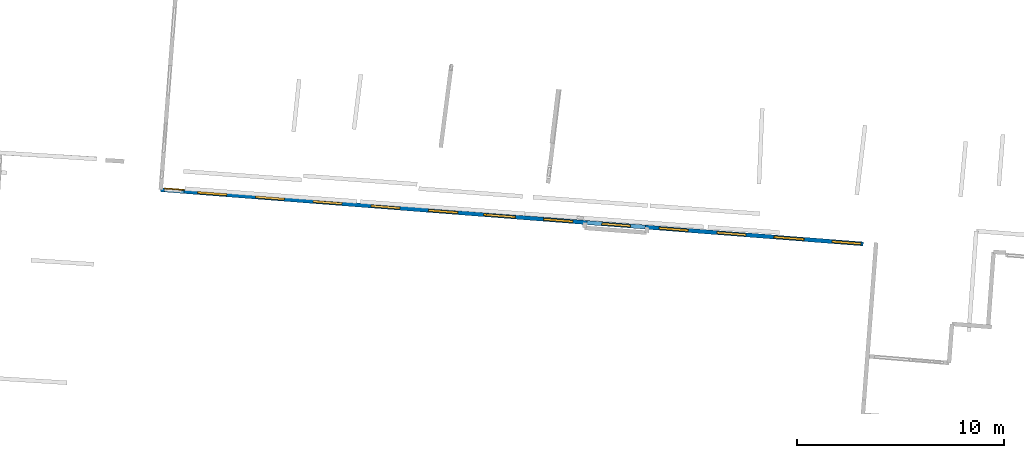
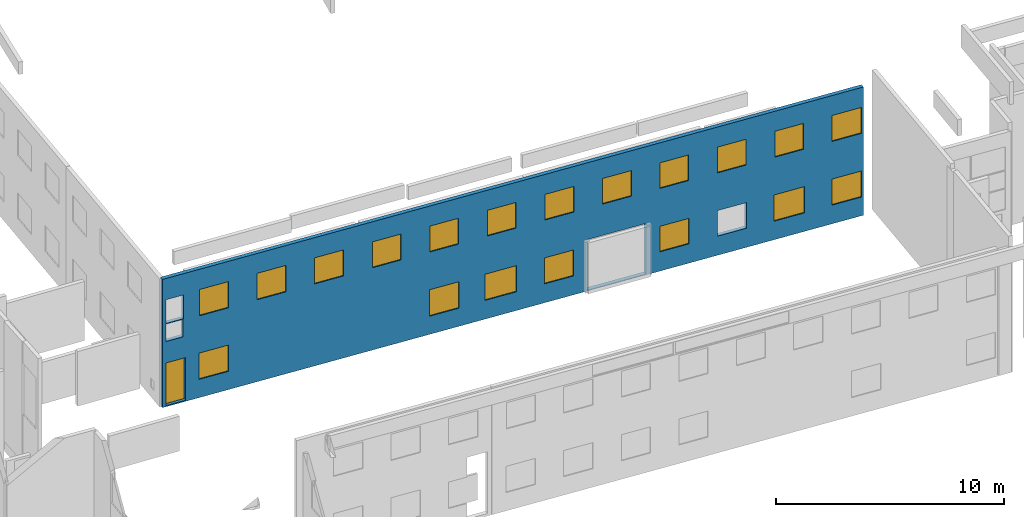
# One storey, part 12 of 27: 19 windows, 1 door, 1 wall, 24 openings.
"""IFC2X3 building model written with IfcOpenShell, lengths in metres."""

from ifc_helpers import new_model, entity, si_unit, converted_unit, derived_unit, direction, frame, frame_2d, origin, origin_2d_with_axis, place, context, subcontext, project, spatial, polyline, rectangle, outline, extrude, source, transform, mapped, material, layer, layer_set, layer_usage, type_object, type_shapes, element, fill, save


model = new_model("IFC2X3")

# Units and contexts
model_context = context("Model", 3, precision=1e-05, world=origin(), true_north=direction((0.0, 1.0)))
body_context = subcontext(model_context, "Body", "Model", "MODEL_VIEW")
ifc_project = project(units=[si_unit("LENGTHUNIT", "METRE"), si_unit("AREAUNIT", "SQUARE_METRE"), si_unit("VOLUMEUNIT", "CUBIC_METRE"), converted_unit("PLANEANGLEUNIT", "DEGREE", entity("IfcRatioMeasure", 0.0174532925199433), si_unit("PLANEANGLEUNIT", "RADIAN"), dimensions=[0, 0, 0, 0, 0, 0, 0]), si_unit("MASSUNIT", "GRAM", prefix="KILO"), derived_unit("MASSDENSITYUNIT", [(si_unit("MASSUNIT", "GRAM", prefix="KILO"), 1), (si_unit("LENGTHUNIT", "METRE"), -3)]), derived_unit("MOMENTOFINERTIAUNIT", [(si_unit("LENGTHUNIT", "METRE"), 4)]), si_unit("TIMEUNIT", "SECOND"), si_unit("FREQUENCYUNIT", "HERTZ"), si_unit("THERMODYNAMICTEMPERATUREUNIT", "DEGREE_CELSIUS"), derived_unit("THERMALTRANSMITTANCEUNIT", [(si_unit("MASSUNIT", "GRAM", prefix="KILO"), 1), (si_unit("THERMODYNAMICTEMPERATUREUNIT", "KELVIN"), -1), (si_unit("TIMEUNIT", "SECOND"), -3)]), derived_unit("VOLUMETRICFLOWRATEUNIT", [(si_unit("LENGTHUNIT", "METRE"), 3), (si_unit("TIMEUNIT", "SECOND"), -1)]), si_unit("ELECTRICCURRENTUNIT", "AMPERE"), si_unit("ELECTRICVOLTAGEUNIT", "VOLT"), si_unit("POWERUNIT", "WATT"), si_unit("FORCEUNIT", "NEWTON", prefix="KILO"), si_unit("ILLUMINANCEUNIT", "LUX"), si_unit("LUMINOUSFLUXUNIT", "LUMEN"), si_unit("LUMINOUSINTENSITYUNIT", "CANDELA"), derived_unit("USERDEFINED", [(si_unit("MASSUNIT", "GRAM", prefix="KILO"), -1), (si_unit("LENGTHUNIT", "METRE"), -2), (si_unit("TIMEUNIT", "SECOND"), 3), (si_unit("LUMINOUSFLUXUNIT", "LUMEN"), 1)]), derived_unit("LINEARVELOCITYUNIT", [(si_unit("LENGTHUNIT", "METRE"), 1), (si_unit("TIMEUNIT", "SECOND"), -1)]), si_unit("PRESSUREUNIT", "PASCAL"), derived_unit("USERDEFINED", [(si_unit("LENGTHUNIT", "METRE"), -2), (si_unit("MASSUNIT", "GRAM", prefix="KILO"), 1), (si_unit("TIMEUNIT", "SECOND"), -2)]), derived_unit("LINEARFORCEUNIT", [(si_unit("MASSUNIT", "GRAM", prefix="KILO"), 1), (si_unit("LENGTHUNIT", "METRE"), 1), (si_unit("TIMEUNIT", "SECOND"), -2), (si_unit("LENGTHUNIT", "METRE"), -1)]), derived_unit("PLANARFORCEUNIT", [(si_unit("MASSUNIT", "GRAM", prefix="KILO"), 1), (si_unit("LENGTHUNIT", "METRE"), 1), (si_unit("TIMEUNIT", "SECOND"), -2), (si_unit("LENGTHUNIT", "METRE"), -2)])], contexts=[model_context])

# Site, building, storey
placement_1 = place(None, origin())
site = spatial("IfcSite", under=ifc_project, at=placement_1, CompositionType="ELEMENT")
building = spatial("IfcBuilding", under=site, at=placement_1, CompositionType="ELEMENT")
storey_placement = place(placement_1, frame((0.0, 0.0, -61.043098449707)))
storey = spatial("IfcBuildingStorey", under=building, at=storey_placement, Name="level_-61.043098", CompositionType="ELEMENT", Elevation=-61.043098449707)

# Wall, openings, windows, door
ifc_material_1 = material(Name="Default wall")
ifc_layer = layer(ifc_material_1, 0.2)
ifc_layer_set = layer_set([ifc_layer], Name="wall_thickness_0.2000")
ifc_layer_usage = layer_usage(ifc_layer_set, "AXIS2", "POSITIVE", -0.1)
wall_type = type_object("IfcWallType", Name="wall_thickness_0.2000", PredefinedType="STANDARD", material=ifc_layer_set)
placement_2 = place(placement_1, frame((0.0, 0.0, -61.0783157348633)))
wall_placement = place(placement_2, frame((-70.5410936106186, 0.364161913204613, 0.0), z_axis=(0.0, 0.0, 1.0), x_axis=(0.997031285356377, -0.0769975065869715, 0.0)))
wall = element("IfcWallStandardCase", 1, at=wall_placement, inside=storey, type_object=wall_type, material=ifc_layer_usage, Name="Wall:863", ObjectType="Wall", context=body_context, shape_type="SweptSolid", body=[
    extrude(outline(polyline([(34.091740570846, -0.1), (34.091740570846, 0.1), (0.0, 0.1), (0.0, -0.1), (34.091740570846, -0.1)])), origin(), (0.0, 0.0, 1.0), 6.869140625),
])
opening_1_placement = place(wall_placement, frame((0.175669529657693, -0.1, 0.0593376159667969)))
opening_1 = element("IfcOpeningElement", 2, at=opening_1_placement, cuts=wall, Name="Opening : 950 x 2285 : 80", ObjectType="Opening", context=body_context, shape_type="SweptSolid", body=[
    extrude(rectangle(XDim=0.95, YDim=2.285, at=frame_2d((1.1425, 0.475), x_axis=(0.0, 1.0))), frame((0.0, 0.0, 0.0), z_axis=(0.0, 1.0, 0.0), x_axis=(0.0, 0.0, 1.0)), (0.0, 0.0, 1.0), 0.2),
])
opening_2_placement = place(wall_placement, frame((20.6733996380134, -0.1, 0.0425682067871094)))
element("IfcOpeningElement", 3, at=opening_2_placement, cuts=wall, Name="Opening : 2840 x 2715 : 81", ObjectType="Opening", context=body_context, shape_type="SweptSolid", body=[
    extrude(rectangle(XDim=2.84, YDim=2.715, at=frame_2d((1.3575, 1.42), x_axis=(0.0, 1.0))), frame((0.0, 0.0, 0.0), z_axis=(0.0, 1.0, 0.0), x_axis=(0.0, 0.0, 1.0)), (0.0, 0.0, 1.0), 0.2),
])
opening_3_placement = place(wall_placement, frame((21.4018079516808, -0.1, 4.43256759643555)))
opening_3 = element("IfcOpeningElement", 4, at=opening_3_placement, cuts=wall, Name="Opening : 1400 x 1370 : 82", ObjectType="Opening", context=body_context, shape_type="SweptSolid", body=[
    extrude(rectangle(XDim=1.4, YDim=1.37, at=frame_2d((0.685, 0.7), x_axis=(0.0, 1.0))), frame((0.0, 0.0, 0.0), z_axis=(0.0, 1.0, 0.0), x_axis=(0.0, 0.0, 1.0)), (0.0, 0.0, 1.0), 0.2),
])
opening_4_placement = place(wall_placement, frame((18.6005650597193, -0.1, 4.42756652832031)))
opening_4 = element("IfcOpeningElement", 5, at=opening_4_placement, cuts=wall, Name="Opening : 1405 x 1370 : 83", ObjectType="Opening", context=body_context, shape_type="SweptSolid", body=[
    extrude(rectangle(XDim=1.405, YDim=1.37, at=frame_2d((0.685, 0.7025), x_axis=(0.0, 1.0))), frame((0.0, 0.0, 0.0), z_axis=(0.0, 1.0, 0.0), x_axis=(0.0, 0.0, 1.0)), (0.0, 0.0, 1.0), 0.2),
])
opening_5_placement = place(wall_placement, frame((4.59927100477917, -0.1, 4.38933563232422)))
opening_5 = element("IfcOpeningElement", 6, at=opening_5_placement, cuts=wall, Name="Opening : 1410 x 1415 : 84", ObjectType="Opening", context=body_context, shape_type="SweptSolid", body=[
    extrude(rectangle(XDim=1.41, YDim=1.415, at=frame_2d((0.7075, 0.705), x_axis=(0.0, 1.0))), frame((0.0, 0.0, 0.0), z_axis=(0.0, 1.0, 0.0), x_axis=(0.0, 0.0, 1.0)), (0.0, 0.0, 1.0), 0.2),
])
opening_6_placement = place(wall_placement, frame((1.79896544522815, -0.1, 4.37933731079102)))
opening_6 = element("IfcOpeningElement", 7, at=opening_6_placement, cuts=wall, Name="Opening : 1405 x 1405 : 85", ObjectType="Opening", context=body_context, shape_type="SweptSolid", body=[
    extrude(rectangle(XDim=1.405, YDim=1.405, at=frame_2d((0.7025, 0.7025), x_axis=(0.0, 1.0))), frame((0.0, 0.0, 0.0), z_axis=(0.0, 1.0, 0.0), x_axis=(0.0, 0.0, 1.0)), (0.0, 0.0, 1.0), 0.2),
])
opening_7_placement = place(wall_placement, frame((7.40003180112796, -0.1, 4.39433670043945)))
opening_7 = element("IfcOpeningElement", 8, at=opening_7_placement, cuts=wall, Name="Opening : 1405 x 1395 : 86", ObjectType="Opening", context=body_context, shape_type="SweptSolid", body=[
    extrude(rectangle(XDim=1.405, YDim=1.395, at=frame_2d((0.6975, 0.7025), x_axis=(0.0, 1.0))), frame((0.0, 0.0, 0.0), z_axis=(0.0, 1.0, 0.0), x_axis=(0.0, 0.0, 1.0)), (0.0, 0.0, 1.0), 0.2),
])
opening_8_placement = place(wall_placement, frame((1.78067692275089, -0.1, 0.979335784912109)))
opening_8 = element("IfcOpeningElement", 9, at=opening_8_placement, cuts=wall, Name="Opening : 1420 x 1405 : 87", ObjectType="Opening", context=body_context, shape_type="SweptSolid", body=[
    extrude(rectangle(XDim=1.42, YDim=1.405, at=frame_2d((0.7025, 0.71), x_axis=(0.0, 1.0))), frame((0.0, 0.0, 0.0), z_axis=(0.0, 1.0, 0.0), x_axis=(0.0, 0.0, 1.0)), (0.0, 0.0, 1.0), 0.2),
])
opening_9_placement = place(wall_placement, frame((24.1869546370559, -0.1, 4.42756652832031)))
opening_9 = element("IfcOpeningElement", 10, at=opening_9_placement, cuts=wall, Name="Opening : 1400 x 1370 : 88", ObjectType="Opening", context=body_context, shape_type="SweptSolid", body=[
    extrude(rectangle(XDim=1.4, YDim=1.37, at=frame_2d((0.685, 0.7), x_axis=(0.0, 1.0))), frame((0.0, 0.0, 0.0), z_axis=(0.0, 1.0, 0.0), x_axis=(0.0, 0.0, 1.0)), (0.0, 0.0, 1.0), 0.2),
])
opening_10_placement = place(wall_placement, frame((29.7875311747154, -0.1, 4.41256713867188)))
opening_10 = element("IfcOpeningElement", 11, at=opening_10_placement, cuts=wall, Name="Opening : 1400 x 1385 : 89", ObjectType="Opening", context=body_context, shape_type="SweptSolid", body=[
    extrude(rectangle(XDim=1.4, YDim=1.385, at=frame_2d((0.6925, 0.7), x_axis=(0.0, 1.0))), frame((0.0, 0.0, 0.0), z_axis=(0.0, 1.0, 0.0), x_axis=(0.0, 0.0, 1.0)), (0.0, 0.0, 1.0), 0.2),
])
opening_11_placement = place(wall_placement, frame((32.5684003285411, -0.1, 4.41256713867188)))
opening_11 = element("IfcOpeningElement", 12, at=opening_11_placement, cuts=wall, Name="Opening : 1420 x 1390 : 90", ObjectType="Opening", context=body_context, shape_type="SweptSolid", body=[
    extrude(rectangle(XDim=1.42, YDim=1.39, at=frame_2d((0.695, 0.71), x_axis=(0.0, 1.0))), frame((0.0, 0.0, 0.0), z_axis=(0.0, 1.0, 0.0), x_axis=(0.0, 0.0, 1.0)), (0.0, 0.0, 1.0), 0.2),
])
opening_12_placement = place(wall_placement, frame((10.2015042481688, -0.1, 4.40756607055664)))
opening_12 = element("IfcOpeningElement", 13, at=opening_12_placement, cuts=wall, Name="Opening : 1405 x 1385 : 91", ObjectType="Opening", context=body_context, shape_type="SweptSolid", body=[
    extrude(rectangle(XDim=1.405, YDim=1.385, at=frame_2d((0.6925, 0.7025), x_axis=(0.0, 1.0))), frame((0.0, 0.0, 0.0), z_axis=(0.0, 1.0, 0.0), x_axis=(0.0, 0.0, 1.0)), (0.0, 0.0, 1.0), 0.2),
])
opening_13_placement = place(wall_placement, frame((12.9975627777284, -0.1, 4.40756607055664)))
opening_13 = element("IfcOpeningElement", 14, at=opening_13_placement, cuts=wall, Name="Opening : 1405 x 1385 : 92", ObjectType="Opening", context=body_context, shape_type="SweptSolid", body=[
    extrude(rectangle(XDim=1.405, YDim=1.385, at=frame_2d((0.6925, 0.7025), x_axis=(0.0, 1.0))), frame((0.0, 0.0, 0.0), z_axis=(0.0, 1.0, 0.0), x_axis=(0.0, 0.0, 1.0)), (0.0, 0.0, 1.0), 0.2),
])
opening_14_placement = place(wall_placement, frame((15.7978721303258, -0.1, 4.41756820678711)))
opening_14 = element("IfcOpeningElement", 15, at=opening_14_placement, cuts=wall, Name="Opening : 1405 x 1375 : 93", ObjectType="Opening", context=body_context, shape_type="SweptSolid", body=[
    extrude(rectangle(XDim=1.405, YDim=1.375, at=frame_2d((0.6875, 0.7025), x_axis=(0.0, 1.0))), frame((0.0, 0.0, 0.0), z_axis=(0.0, 1.0, 0.0), x_axis=(0.0, 0.0, 1.0)), (0.0, 0.0, 1.0), 0.2),
])
opening_15_placement = place(wall_placement, frame((26.9919317277781, -0.1, 4.41256713867188)))
opening_15 = element("IfcOpeningElement", 16, at=opening_15_placement, cuts=wall, Name="Opening : 1400 x 1380 : 94", ObjectType="Opening", context=body_context, shape_type="SweptSolid", body=[
    extrude(rectangle(XDim=1.4, YDim=1.38, at=frame_2d((0.69, 0.7), x_axis=(0.0, 1.0))), frame((0.0, 0.0, 0.0), z_axis=(0.0, 1.0, 0.0), x_axis=(0.0, 0.0, 1.0)), (0.0, 0.0, 1.0), 0.2),
])
opening_16_placement = place(wall_placement, frame((15.6733990489944, -0.1, 1.00256729125977)))
opening_16 = element("IfcOpeningElement", 17, at=opening_16_placement, cuts=wall, Name="Opening : 1535 x 1400 : 95", ObjectType="Opening", context=body_context, shape_type="SweptSolid", body=[
    extrude(rectangle(XDim=1.535, YDim=1.4, at=frame_2d((0.7, 0.7675), x_axis=(0.0, 1.0))), frame((0.0, 0.0, 0.0), z_axis=(0.0, 1.0, 0.0), x_axis=(0.0, 0.0, 1.0)), (0.0, 0.0, 1.0), 0.2),
])
opening_17_placement = place(wall_placement, frame((18.5683994261943, -0.1, 1.01256561279297)))
opening_17 = element("IfcOpeningElement", 18, at=opening_17_placement, cuts=wall, Name="Opening : 1425 x 1390 : 96", ObjectType="Opening", context=body_context, shape_type="SweptSolid", body=[
    extrude(rectangle(XDim=1.425, YDim=1.39, at=frame_2d((0.695, 0.7125), x_axis=(0.0, 1.0))), frame((0.0, 0.0, 0.0), z_axis=(0.0, 1.0, 0.0), x_axis=(0.0, 0.0, 1.0)), (0.0, 0.0, 1.0), 0.2),
])
opening_18_placement = place(wall_placement, frame((24.1934015219894, -0.1, 1.03256607055664)))
opening_18 = element("IfcOpeningElement", 19, at=opening_18_placement, cuts=wall, Name="Opening : 1405 x 1365 : 97", ObjectType="Opening", context=body_context, shape_type="SweptSolid", body=[
    extrude(rectangle(XDim=1.405, YDim=1.365, at=frame_2d((0.6825, 0.7025), x_axis=(0.0, 1.0))), frame((0.0, 0.0, 0.0), z_axis=(0.0, 1.0, 0.0), x_axis=(0.0, 0.0, 1.0)), (0.0, 0.0, 1.0), 0.2),
])
opening_19_placement = place(wall_placement, frame((29.7484020893475, -0.1, 0.992565155029297)))
opening_19 = element("IfcOpeningElement", 20, at=opening_19_placement, cuts=wall, Name="Opening : 1480 x 1405 : 98", ObjectType="Opening", context=body_context, shape_type="SweptSolid", body=[
    extrude(rectangle(XDim=1.48, YDim=1.405, at=frame_2d((0.7025, 0.74), x_axis=(0.0, 1.0))), frame((0.0, 0.0, 0.0), z_axis=(0.0, 1.0, 0.0), x_axis=(0.0, 0.0, 1.0)), (0.0, 0.0, 1.0), 0.2),
])
opening_20_placement = place(wall_placement, frame((32.5734009472892, -0.1, 1.00256729125977)))
opening_20 = element("IfcOpeningElement", 21, at=opening_20_placement, cuts=wall, Name="Opening : 1415 x 1395 : 99", ObjectType="Opening", context=body_context, shape_type="SweptSolid", body=[
    extrude(rectangle(XDim=1.415, YDim=1.395, at=frame_2d((0.6975, 0.7075), x_axis=(0.0, 1.0))), frame((0.0, 0.0, 0.0), z_axis=(0.0, 1.0, 0.0), x_axis=(0.0, 0.0, 1.0)), (0.0, 0.0, 1.0), 0.2),
])
opening_21_placement = place(wall_placement, frame((12.9833987386074, -0.1, 0.972564697265625)))
opening_21 = element("IfcOpeningElement", 22, at=opening_21_placement, cuts=wall, Name="Opening : 1435 x 1415 : 100", ObjectType="Opening", context=body_context, shape_type="SweptSolid", body=[
    extrude(rectangle(XDim=1.435, YDim=1.415, at=frame_2d((0.7075, 0.7175), x_axis=(0.0, 1.0))), frame((0.0, 0.0, 0.0), z_axis=(0.0, 1.0, 0.0), x_axis=(0.0, 0.0, 1.0)), (0.0, 0.0, 1.0), 0.2),
])
opening_22_placement = place(wall_placement, frame((26.9833996317755, -0.1, 1.02256774902344)))
element("IfcOpeningElement", 23, at=opening_22_placement, cuts=wall, Name="Opening : 1410 x 1370 : 101", ObjectType="Opening", context=body_context, shape_type="SweptSolid", body=[
    extrude(rectangle(XDim=1.41, YDim=1.37, at=frame_2d((0.685, 0.705), x_axis=(0.0, 1.0))), frame((0.0, 0.0, 0.0), z_axis=(0.0, 1.0, 0.0), x_axis=(0.0, 0.0, 1.0)), (0.0, 0.0, 1.0), 0.2),
])
opening_23_placement = place(wall_placement, frame((0.17339684269828, -0.1, 4.45256805419922)))
element("IfcOpeningElement", 24, at=opening_23_placement, cuts=wall, Name="Opening : 835 x 1275 : 102", ObjectType="Opening", context=body_context, shape_type="SweptSolid", body=[
    extrude(rectangle(XDim=0.835, YDim=1.275, at=frame_2d((0.6375, 0.4175), x_axis=(0.0, 1.0))), frame((0.0, 0.0, 0.0), z_axis=(0.0, 1.0, 0.0), x_axis=(0.0, 0.0, 1.0)), (0.0, 0.0, 1.0), 0.2),
])
opening_24_placement = place(wall_placement, frame((0.17339684269828, -0.1, 3.4925651550293)))
element("IfcOpeningElement", 25, at=opening_24_placement, cuts=wall, Name="Opening : 830 x 930 : 103", ObjectType="Opening", context=body_context, shape_type="SweptSolid", body=[
    extrude(rectangle(XDim=0.83, YDim=0.93, at=frame_2d((0.465, 0.415), x_axis=(0.0, 1.0))), frame((0.0, 0.0, 0.0), z_axis=(0.0, 1.0, 0.0), x_axis=(0.0, 0.0, 1.0)), (0.0, 0.0, 1.0), 0.2),
])
ifc_material_2 = material(Name="Window Default")
window_style_1 = type_object("IfcWindowStyle", Name="Window : 1420 x 1390mm", ConstructionType="NOTDEFINED", OperationType="NOTDEFINED", ParameterTakesPrecedence=False, Sizeable=False, material=ifc_material_2)
shared_shape_1 = source(origin(), body_context, "Body", "SweptSolid", [
    extrude(rectangle(XDim=0.1, YDim=1.42, at=origin_2d_with_axis()), frame((0.71, 0.1, 0.0), z_axis=(0.0, 0.0, 1.0), x_axis=(0.0, 1.0, 0.0)), (0.0, 0.0, 1.0), 1.39),
])
type_shapes(window_style_1, [shared_shape_1])
window_1_placement = place(opening_11_placement, origin())
window_1 = element("IfcWindow", 26, at=window_1_placement, inside=storey, type_object=window_style_1, Name="Window : 1420 x 1390mm : 79", ObjectType="Window : 1420 x 1390mm", OverallHeight=1.39, OverallWidth=1.42, context=body_context, shape_type="MappedRepresentation", body=[
    mapped(shared_shape_1, transform((0.0, 0.0, 0.0), scale=1.0)),
])
fill(opening_11, window_1)
window_style_2 = type_object("IfcWindowStyle", Name="Window : 1405 x 1405mm", ConstructionType="NOTDEFINED", OperationType="NOTDEFINED", ParameterTakesPrecedence=False, Sizeable=False, material=ifc_material_2)
shared_shape_2 = source(origin(), body_context, "Body", "SweptSolid", [
    extrude(rectangle(XDim=0.1, YDim=1.405, at=origin_2d_with_axis()), frame((0.7025, 0.1, 0.0), z_axis=(0.0, 0.0, 1.0), x_axis=(0.0, 1.0, 0.0)), (0.0, 0.0, 1.0), 1.405),
])
type_shapes(window_style_2, [shared_shape_2])
window_2_placement = place(opening_6_placement, origin())
window_2 = element("IfcWindow", 27, at=window_2_placement, inside=storey, type_object=window_style_2, Name="Window : 1405 x 1405mm : 74", ObjectType="Window : 1405 x 1405mm", OverallHeight=1.405, OverallWidth=1.405, context=body_context, shape_type="MappedRepresentation", body=[
    mapped(shared_shape_2, transform((0.0, 0.0, 0.0), scale=1.0)),
])
fill(opening_6, window_2)
window_style_3 = type_object("IfcWindowStyle", Name="Window : 1420 x 1405mm", ConstructionType="NOTDEFINED", OperationType="NOTDEFINED", ParameterTakesPrecedence=False, Sizeable=False, material=ifc_material_2)
shared_shape_3 = source(origin(), body_context, "Body", "SweptSolid", [
    extrude(rectangle(XDim=0.1, YDim=1.42, at=origin_2d_with_axis()), frame((0.71, 0.1, 0.0), z_axis=(0.0, 0.0, 1.0), x_axis=(0.0, 1.0, 0.0)), (0.0, 0.0, 1.0), 1.405),
])
type_shapes(window_style_3, [shared_shape_3])
window_3_placement = place(opening_8_placement, origin())
window_3 = element("IfcWindow", 28, at=window_3_placement, inside=storey, type_object=window_style_3, Name="Window : 1420 x 1405mm : 76", ObjectType="Window : 1420 x 1405mm", OverallHeight=1.405, OverallWidth=1.42, context=body_context, shape_type="MappedRepresentation", body=[
    mapped(shared_shape_3, transform((0.0, 0.0, 0.0), scale=1.0)),
])
fill(opening_8, window_3)
ifc_material_3 = material(Name="Door Panel")
door_style = type_object("IfcDoorStyle", Name="Door : 950 x 2285mm", ConstructionType="NOTDEFINED", OperationType="SINGLE_SWING_RIGHT", ParameterTakesPrecedence=False, Sizeable=False, material=ifc_material_3)
shared_shape_4 = source(origin(), body_context, "Body", "SweptSolid", [
    extrude(rectangle(XDim=0.05, YDim=0.95, at=origin_2d_with_axis()), frame((0.475, 0.175, 0.0), z_axis=(0.0, 0.0, 1.0), x_axis=(0.0, 1.0, 0.0)), (0.0, 0.0, 1.0), 2.285),
])
type_shapes(door_style, [shared_shape_4])
door_placement = place(opening_1_placement, origin())
door = element("IfcDoor", 29, at=door_placement, inside=storey, type_object=door_style, Name="Door : 950 x 2285mm : 4", ObjectType="Door : 950 x 2285mm", OverallHeight=2.285, OverallWidth=0.95, context=body_context, shape_type="MappedRepresentation", body=[
    mapped(shared_shape_4, transform((0.0, 0.0, 0.0), scale=1.0)),
])
fill(opening_1, door)
window_style_4 = type_object("IfcWindowStyle", Name="Window : 1400 x 1370mm", ConstructionType="NOTDEFINED", OperationType="NOTDEFINED", ParameterTakesPrecedence=False, Sizeable=False, material=ifc_material_2)
shared_shape_5 = source(origin(), body_context, "Body", "SweptSolid", [
    extrude(rectangle(XDim=0.1, YDim=1.4, at=origin_2d_with_axis()), frame((0.7, 0.1, 0.0), z_axis=(0.0, 0.0, 1.0), x_axis=(0.0, 1.0, 0.0)), (0.0, 0.0, 1.0), 1.37),
])
type_shapes(window_style_4, [shared_shape_5])
window_4_placement = place(opening_3_placement, origin())
window_4 = element("IfcWindow", 30, at=window_4_placement, inside=storey, type_object=window_style_4, Name="Window : 1400 x 1370mm : 71", ObjectType="Window : 1400 x 1370mm", OverallHeight=1.37, OverallWidth=1.4, context=body_context, shape_type="MappedRepresentation", body=[
    mapped(shared_shape_5, transform((0.0, 0.0, 0.0), scale=1.0)),
])
fill(opening_3, window_4)
window_5_placement = place(opening_9_placement, origin())
window_5 = element("IfcWindow", 31, at=window_5_placement, inside=storey, type_object=window_style_4, Name="Window : 1400 x 1370mm : 77", ObjectType="Window : 1400 x 1370mm", OverallHeight=1.37, OverallWidth=1.4, context=body_context, shape_type="MappedRepresentation", body=[
    mapped(shared_shape_5, transform((0.0, 0.0, 0.0), scale=1.0)),
])
fill(opening_9, window_5)
window_style_5 = type_object("IfcWindowStyle", Name="Window : 1405 x 1370mm", ConstructionType="NOTDEFINED", OperationType="NOTDEFINED", ParameterTakesPrecedence=False, Sizeable=False, material=ifc_material_2)
shared_shape_6 = source(origin(), body_context, "Body", "SweptSolid", [
    extrude(rectangle(XDim=0.1, YDim=1.405, at=origin_2d_with_axis()), frame((0.7025, 0.1, 0.0), z_axis=(0.0, 0.0, 1.0), x_axis=(0.0, 1.0, 0.0)), (0.0, 0.0, 1.0), 1.37),
])
type_shapes(window_style_5, [shared_shape_6])
window_6_placement = place(opening_4_placement, origin())
window_6 = element("IfcWindow", 32, at=window_6_placement, inside=storey, type_object=window_style_5, Name="Window : 1405 x 1370mm : 72", ObjectType="Window : 1405 x 1370mm", OverallHeight=1.37, OverallWidth=1.405, context=body_context, shape_type="MappedRepresentation", body=[
    mapped(shared_shape_6, transform((0.0, 0.0, 0.0), scale=1.0)),
])
fill(opening_4, window_6)
window_style_6 = type_object("IfcWindowStyle", Name="Window : 1410 x 1415mm", ConstructionType="NOTDEFINED", OperationType="NOTDEFINED", ParameterTakesPrecedence=False, Sizeable=False, material=ifc_material_2)
shared_shape_7 = source(origin(), body_context, "Body", "SweptSolid", [
    extrude(rectangle(XDim=0.1, YDim=1.41, at=origin_2d_with_axis()), frame((0.705, 0.1, 0.0), z_axis=(0.0, 0.0, 1.0), x_axis=(0.0, 1.0, 0.0)), (0.0, 0.0, 1.0), 1.415),
])
type_shapes(window_style_6, [shared_shape_7])
window_7_placement = place(opening_5_placement, origin())
window_7 = element("IfcWindow", 33, at=window_7_placement, inside=storey, type_object=window_style_6, Name="Window : 1410 x 1415mm : 73", ObjectType="Window : 1410 x 1415mm", OverallHeight=1.415, OverallWidth=1.41, context=body_context, shape_type="MappedRepresentation", body=[
    mapped(shared_shape_7, transform((0.0, 0.0, 0.0), scale=1.0)),
])
fill(opening_5, window_7)
window_style_7 = type_object("IfcWindowStyle", Name="Window : 1405 x 1395mm", ConstructionType="NOTDEFINED", OperationType="NOTDEFINED", ParameterTakesPrecedence=False, Sizeable=False, material=ifc_material_2)
shared_shape_8 = source(origin(), body_context, "Body", "SweptSolid", [
    extrude(rectangle(XDim=0.1, YDim=1.405, at=origin_2d_with_axis()), frame((0.7025, 0.1, 0.0), z_axis=(0.0, 0.0, 1.0), x_axis=(0.0, 1.0, 0.0)), (0.0, 0.0, 1.0), 1.395),
])
type_shapes(window_style_7, [shared_shape_8])
window_8_placement = place(opening_7_placement, origin())
window_8 = element("IfcWindow", 34, at=window_8_placement, inside=storey, type_object=window_style_7, Name="Window : 1405 x 1395mm : 75", ObjectType="Window : 1405 x 1395mm", OverallHeight=1.395, OverallWidth=1.405, context=body_context, shape_type="MappedRepresentation", body=[
    mapped(shared_shape_8, transform((0.0, 0.0, 0.0), scale=1.0)),
])
fill(opening_7, window_8)
window_style_8 = type_object("IfcWindowStyle", Name="Window : 1400 x 1385mm", ConstructionType="NOTDEFINED", OperationType="NOTDEFINED", ParameterTakesPrecedence=False, Sizeable=False, material=ifc_material_2)
shared_shape_9 = source(origin(), body_context, "Body", "SweptSolid", [
    extrude(rectangle(XDim=0.1, YDim=1.4, at=origin_2d_with_axis()), frame((0.7, 0.1, 0.0), z_axis=(0.0, 0.0, 1.0), x_axis=(0.0, 1.0, 0.0)), (0.0, 0.0, 1.0), 1.385),
])
type_shapes(window_style_8, [shared_shape_9])
window_9_placement = place(opening_10_placement, origin())
window_9 = element("IfcWindow", 35, at=window_9_placement, inside=storey, type_object=window_style_8, Name="Window : 1400 x 1385mm : 78", ObjectType="Window : 1400 x 1385mm", OverallHeight=1.385, OverallWidth=1.4, context=body_context, shape_type="MappedRepresentation", body=[
    mapped(shared_shape_9, transform((0.0, 0.0, 0.0), scale=1.0)),
])
fill(opening_10, window_9)
window_style_9 = type_object("IfcWindowStyle", Name="Window : 1405 x 1385mm", ConstructionType="NOTDEFINED", OperationType="NOTDEFINED", ParameterTakesPrecedence=False, Sizeable=False, material=ifc_material_2)
shared_shape_10 = source(origin(), body_context, "Body", "SweptSolid", [
    extrude(rectangle(XDim=0.1, YDim=1.405, at=origin_2d_with_axis()), frame((0.7025, 0.1, 0.0), z_axis=(0.0, 0.0, 1.0), x_axis=(0.0, 1.0, 0.0)), (0.0, 0.0, 1.0), 1.385),
])
type_shapes(window_style_9, [shared_shape_10])
window_10_placement = place(opening_12_placement, origin())
window_10 = element("IfcWindow", 36, at=window_10_placement, inside=storey, type_object=window_style_9, Name="Window : 1405 x 1385mm : 80", ObjectType="Window : 1405 x 1385mm", OverallHeight=1.385, OverallWidth=1.405, context=body_context, shape_type="MappedRepresentation", body=[
    mapped(shared_shape_10, transform((0.0, 0.0, 0.0), scale=1.0)),
])
fill(opening_12, window_10)
window_11_placement = place(opening_13_placement, origin())
window_11 = element("IfcWindow", 37, at=window_11_placement, inside=storey, type_object=window_style_9, Name="Window : 1405 x 1385mm : 81", ObjectType="Window : 1405 x 1385mm", OverallHeight=1.385, OverallWidth=1.405, context=body_context, shape_type="MappedRepresentation", body=[
    mapped(shared_shape_10, transform((0.0, 0.0, 0.0), scale=1.0)),
])
fill(opening_13, window_11)
window_style_10 = type_object("IfcWindowStyle", Name="Window : 1405 x 1375mm", ConstructionType="NOTDEFINED", OperationType="NOTDEFINED", ParameterTakesPrecedence=False, Sizeable=False, material=ifc_material_2)
shared_shape_11 = source(origin(), body_context, "Body", "SweptSolid", [
    extrude(rectangle(XDim=0.1, YDim=1.405, at=origin_2d_with_axis()), frame((0.7025, 0.1, 0.0), z_axis=(0.0, 0.0, 1.0), x_axis=(0.0, 1.0, 0.0)), (0.0, 0.0, 1.0), 1.375),
])
type_shapes(window_style_10, [shared_shape_11])
window_12_placement = place(opening_14_placement, origin())
window_12 = element("IfcWindow", 38, at=window_12_placement, inside=storey, type_object=window_style_10, Name="Window : 1405 x 1375mm : 82", ObjectType="Window : 1405 x 1375mm", OverallHeight=1.375, OverallWidth=1.405, context=body_context, shape_type="MappedRepresentation", body=[
    mapped(shared_shape_11, transform((0.0, 0.0, 0.0), scale=1.0)),
])
fill(opening_14, window_12)
window_style_11 = type_object("IfcWindowStyle", Name="Window : 1400 x 1380mm", ConstructionType="NOTDEFINED", OperationType="NOTDEFINED", ParameterTakesPrecedence=False, Sizeable=False, material=ifc_material_2)
shared_shape_12 = source(origin(), body_context, "Body", "SweptSolid", [
    extrude(rectangle(XDim=0.1, YDim=1.4, at=origin_2d_with_axis()), frame((0.7, 0.1, 0.0), z_axis=(0.0, 0.0, 1.0), x_axis=(0.0, 1.0, 0.0)), (0.0, 0.0, 1.0), 1.38),
])
type_shapes(window_style_11, [shared_shape_12])
window_13_placement = place(opening_15_placement, origin())
window_13 = element("IfcWindow", 39, at=window_13_placement, inside=storey, type_object=window_style_11, Name="Window : 1400 x 1380mm : 83", ObjectType="Window : 1400 x 1380mm", OverallHeight=1.38, OverallWidth=1.4, context=body_context, shape_type="MappedRepresentation", body=[
    mapped(shared_shape_12, transform((0.0, 0.0, 0.0), scale=1.0)),
])
fill(opening_15, window_13)
window_style_12 = type_object("IfcWindowStyle", Name="Window : 1535 x 1400mm", ConstructionType="NOTDEFINED", OperationType="NOTDEFINED", ParameterTakesPrecedence=False, Sizeable=False, material=ifc_material_2)
shared_shape_13 = source(origin(), body_context, "Body", "SweptSolid", [
    extrude(rectangle(XDim=0.1, YDim=1.535, at=origin_2d_with_axis()), frame((0.7675, 0.1, 0.0), z_axis=(0.0, 0.0, 1.0), x_axis=(0.0, 1.0, 0.0)), (0.0, 0.0, 1.0), 1.4),
])
type_shapes(window_style_12, [shared_shape_13])
window_14_placement = place(opening_16_placement, origin())
window_14 = element("IfcWindow", 40, at=window_14_placement, inside=storey, type_object=window_style_12, Name="Window : 1535 x 1400mm : 84", ObjectType="Window : 1535 x 1400mm", OverallHeight=1.4, OverallWidth=1.535, context=body_context, shape_type="MappedRepresentation", body=[
    mapped(shared_shape_13, transform((0.0, 0.0, 0.0), scale=1.0)),
])
fill(opening_16, window_14)
window_style_13 = type_object("IfcWindowStyle", Name="Window : 1425 x 1390mm", ConstructionType="NOTDEFINED", OperationType="NOTDEFINED", ParameterTakesPrecedence=False, Sizeable=False, material=ifc_material_2)
shared_shape_14 = source(origin(), body_context, "Body", "SweptSolid", [
    extrude(rectangle(XDim=0.1, YDim=1.425, at=origin_2d_with_axis()), frame((0.7125, 0.1, 0.0), z_axis=(0.0, 0.0, 1.0), x_axis=(0.0, 1.0, 0.0)), (0.0, 0.0, 1.0), 1.39),
])
type_shapes(window_style_13, [shared_shape_14])
window_15_placement = place(opening_17_placement, origin())
window_15 = element("IfcWindow", 41, at=window_15_placement, inside=storey, type_object=window_style_13, Name="Window : 1425 x 1390mm : 85", ObjectType="Window : 1425 x 1390mm", OverallHeight=1.39, OverallWidth=1.425, context=body_context, shape_type="MappedRepresentation", body=[
    mapped(shared_shape_14, transform((0.0, 0.0, 0.0), scale=1.0)),
])
fill(opening_17, window_15)
window_style_14 = type_object("IfcWindowStyle", Name="Window : 1405 x 1365mm", ConstructionType="NOTDEFINED", OperationType="NOTDEFINED", ParameterTakesPrecedence=False, Sizeable=False, material=ifc_material_2)
shared_shape_15 = source(origin(), body_context, "Body", "SweptSolid", [
    extrude(rectangle(XDim=0.1, YDim=1.405, at=origin_2d_with_axis()), frame((0.7025, 0.1, 0.0), z_axis=(0.0, 0.0, 1.0), x_axis=(0.0, 1.0, 0.0)), (0.0, 0.0, 1.0), 1.365),
])
type_shapes(window_style_14, [shared_shape_15])
window_16_placement = place(opening_18_placement, origin())
window_16 = element("IfcWindow", 42, at=window_16_placement, inside=storey, type_object=window_style_14, Name="Window : 1405 x 1365mm : 86", ObjectType="Window : 1405 x 1365mm", OverallHeight=1.365, OverallWidth=1.405, context=body_context, shape_type="MappedRepresentation", body=[
    mapped(shared_shape_15, transform((0.0, 0.0, 0.0), scale=1.0)),
])
fill(opening_18, window_16)
window_style_15 = type_object("IfcWindowStyle", Name="Window : 1480 x 1405mm", ConstructionType="NOTDEFINED", OperationType="NOTDEFINED", ParameterTakesPrecedence=False, Sizeable=False, material=ifc_material_2)
shared_shape_16 = source(origin(), body_context, "Body", "SweptSolid", [
    extrude(rectangle(XDim=0.1, YDim=1.48, at=origin_2d_with_axis()), frame((0.74, 0.1, 0.0), z_axis=(0.0, 0.0, 1.0), x_axis=(0.0, 1.0, 0.0)), (0.0, 0.0, 1.0), 1.405),
])
type_shapes(window_style_15, [shared_shape_16])
window_17_placement = place(opening_19_placement, origin())
window_17 = element("IfcWindow", 43, at=window_17_placement, inside=storey, type_object=window_style_15, Name="Window : 1480 x 1405mm : 87", ObjectType="Window : 1480 x 1405mm", OverallHeight=1.405, OverallWidth=1.48, context=body_context, shape_type="MappedRepresentation", body=[
    mapped(shared_shape_16, transform((0.0, 0.0, 0.0), scale=1.0)),
])
fill(opening_19, window_17)
window_style_16 = type_object("IfcWindowStyle", Name="Window : 1415 x 1395mm", ConstructionType="NOTDEFINED", OperationType="NOTDEFINED", ParameterTakesPrecedence=False, Sizeable=False, material=ifc_material_2)
shared_shape_17 = source(origin(), body_context, "Body", "SweptSolid", [
    extrude(rectangle(XDim=0.1, YDim=1.415, at=origin_2d_with_axis()), frame((0.7075, 0.1, 0.0), z_axis=(0.0, 0.0, 1.0), x_axis=(0.0, 1.0, 0.0)), (0.0, 0.0, 1.0), 1.395),
])
type_shapes(window_style_16, [shared_shape_17])
window_18_placement = place(opening_20_placement, origin())
window_18 = element("IfcWindow", 44, at=window_18_placement, inside=storey, type_object=window_style_16, Name="Window : 1415 x 1395mm : 88", ObjectType="Window : 1415 x 1395mm", OverallHeight=1.395, OverallWidth=1.415, context=body_context, shape_type="MappedRepresentation", body=[
    mapped(shared_shape_17, transform((0.0, 0.0, 0.0), scale=1.0)),
])
fill(opening_20, window_18)
window_style_17 = type_object("IfcWindowStyle", Name="Window : 1435 x 1415mm", ConstructionType="NOTDEFINED", OperationType="NOTDEFINED", ParameterTakesPrecedence=False, Sizeable=False, material=ifc_material_2)
shared_shape_18 = source(origin(), body_context, "Body", "SweptSolid", [
    extrude(rectangle(XDim=0.1, YDim=1.435, at=origin_2d_with_axis()), frame((0.7175, 0.1, 0.0), z_axis=(0.0, 0.0, 1.0), x_axis=(0.0, 1.0, 0.0)), (0.0, 0.0, 1.0), 1.415),
])
type_shapes(window_style_17, [shared_shape_18])
window_19_placement = place(opening_21_placement, origin())
window_19 = element("IfcWindow", 45, at=window_19_placement, inside=storey, type_object=window_style_17, Name="Window : 1435 x 1415mm : 89", ObjectType="Window : 1435 x 1415mm", OverallHeight=1.415, OverallWidth=1.435, context=body_context, shape_type="MappedRepresentation", body=[
    mapped(shared_shape_18, transform((0.0, 0.0, 0.0), scale=1.0)),
])
fill(opening_21, window_19)

save(model, "model.ifc")
